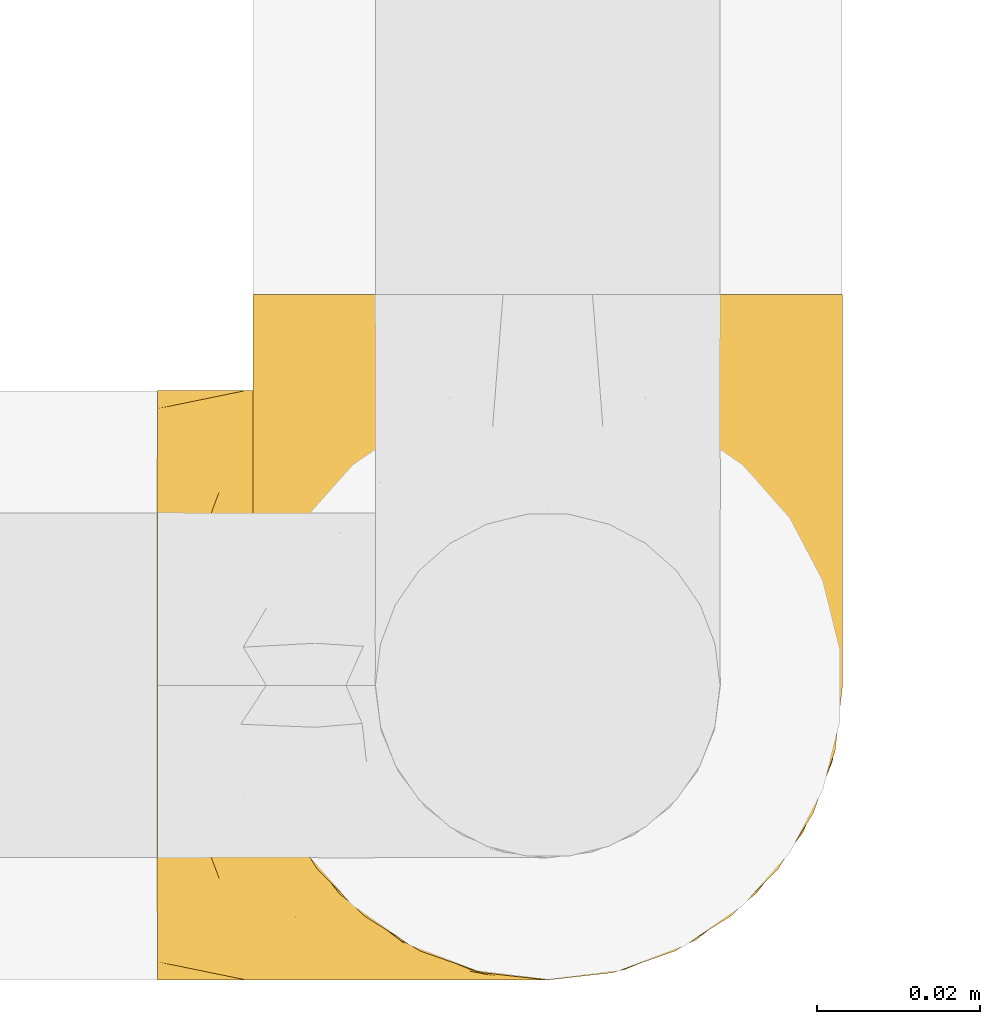
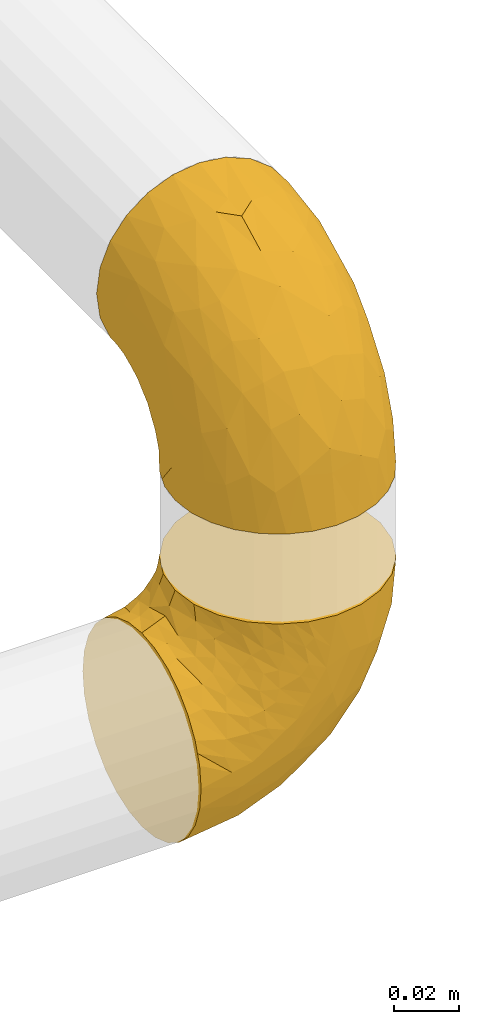
# One storey, part 16 of 39: 2 coverings.
"""IFC2X3 building model written with IfcOpenShell, lengths in millimetres."""

import ifcopenshell
import ifcopenshell.guid

model = None  # the IFC model being written
_history = None  # IfcOwnerHistory: only IFC2X3 demands one
_inside = {}  # id of a spatial element -> (the spatial element, [elements in it])
_under = {}  # id of a project, library or spatial element -> (it, [spatial elements below it])
_declared = {}  # id of a project -> (the project, [libraries it declares])
_typed = {}  # id of a type object -> (the type object, [elements of that type])
_made_of = {}  # id of a material, layer set ... -> (it, [elements and type objects made of it])


def new_model(schema):
    """Start an empty IFC model of exactly this schema.

    Asked for "IFC4X3", IfcOpenShell would pick the latest addendum, in which some entities
    have other attributes; the version numbers below select the first issue.
    IFC2X3 requires an IfcOwnerHistory on every rooted entity: one is made here for all.
    """
    global model, _history
    if schema == "IFC4X3":
        model = ifcopenshell.file(schema_version=(4, 3, 0, 0))
    else:
        model = ifcopenshell.file(schema=schema)
    _inside.clear()
    _under.clear()
    _declared.clear()
    _typed.clear()
    _made_of.clear()
    _history = None
    if model.schema == "IFC2X3":
        org = make("IfcOrganization", Name="unknown")
        user = make(
            "IfcPersonAndOrganization",
            ThePerson=make("IfcPerson", FamilyName="unknown"),
            TheOrganization=org,
        )
        app = make(
            "IfcApplication",
            ApplicationDeveloper=org,
            Version="unknown",
            ApplicationFullName="unknown",
            ApplicationIdentifier="unknown",
        )
        _history = make(
            "IfcOwnerHistory",
            OwningUser=user,
            OwningApplication=app,
            ChangeAction="ADDED",
            CreationDate=0,
        )
    return model


def make(cls, **values):
    """One entity of the class cls with the attributes given. An attribute that is None is left unset."""
    return model.create_entity(
        cls, **{name: value for name, value in values.items() if value is not None}
    )


def entity(cls, *values):
    """Any entity or typed value of the class cls, its attributes in the order of the schema. None: left unset."""
    e = model.create_entity(cls)
    for i, value in enumerate(values):
        if value is not None:
            e[i] = value
    return e


def rooted(cls, **values):
    """An entity with a GlobalId (a new one), such as an element, a storey or a relation."""
    return make(cls, GlobalId=ifcopenshell.guid.new(), OwnerHistory=_history, **values)


def si_unit(unit_type, name, prefix=None):
    """IfcSIUnit, for example si_unit("LENGTHUNIT", "METRE", prefix="MILLI")."""
    return make("IfcSIUnit", UnitType=unit_type, Prefix=prefix, Name=name)


def converted_unit(unit_type, name, factor, base, dimensions=None, offset=None):
    """IfcConversionBasedUnit, such as the inch: factor (a typed value) times the base unit."""
    return make(
        "IfcConversionBasedUnit"
        if offset is None
        else "IfcConversionBasedUnitWithOffset",
        ConversionOffset=offset,
        Dimensions=None
        if dimensions is None
        else entity("IfcDimensionalExponents", *dimensions),
        UnitType=unit_type,
        Name=name,
        ConversionFactor=make(
            "IfcMeasureWithUnit", ValueComponent=factor, UnitComponent=base
        ),
    )


def derived_unit(unit_type, elements):
    """IfcDerivedUnit: a product of units, each with its exponent."""
    return make(
        "IfcDerivedUnit",
        Elements=[
            make("IfcDerivedUnitElement", Unit=unit, Exponent=power)
            for unit, power in elements
        ],
        UnitType=unit_type,
    )


def assignment(units):
    """IfcUnitAssignment: the units of a project."""
    return None if units is None else make("IfcUnitAssignment", Units=units)


def point(xyz):
    """IfcCartesianPoint."""
    return None if xyz is None else make("IfcCartesianPoint", Coordinates=xyz)


def direction(xyz):
    """IfcDirection."""
    return None if xyz is None else make("IfcDirection", DirectionRatios=xyz)


def frame(location, z_axis=None, x_axis=None):
    """IfcAxis2Placement3D, a coordinate frame: its origin and axes. An axis left out is left unset."""
    return make(
        "IfcAxis2Placement3D",
        Location=point(location),
        Axis=direction(z_axis),
        RefDirection=direction(x_axis),
    )


def origin():
    """The frame at (0, 0, 0) with its axes left unset."""
    return frame((0.0, 0.0, 0.0))


def place(relative_to, where):
    """IfcLocalPlacement: puts the frame where relative to a parent placement (None: the world)."""
    return make(
        "IfcLocalPlacement", PlacementRelTo=relative_to, RelativePlacement=where
    )


def context(
    kind, dimensions, precision=None, world=None, true_north=None, identifier=None
):
    """IfcGeometricRepresentationContext, for example the 3D "Model" context."""
    return make(
        "IfcGeometricRepresentationContext",
        ContextIdentifier=identifier,
        ContextType=kind,
        CoordinateSpaceDimension=dimensions,
        Precision=precision,
        WorldCoordinateSystem=world,
        TrueNorth=true_north,
    )


def subcontext(parent, identifier, kind, view, scale=None):
    """IfcGeometricRepresentationSubContext, for example "Body" below "Model"."""
    return make(
        "IfcGeometricRepresentationSubContext",
        ContextIdentifier=identifier,
        ContextType=kind,
        ParentContext=parent,
        TargetScale=scale,
        TargetView=view,
    )


def project(units=None, contexts=None):
    """IfcProject with its units and contexts."""
    return rooted(
        "IfcProject",
        Name="project",
        RepresentationContexts=contexts,
        UnitsInContext=assignment(units),
    )


def spatial(cls, under=None, at=None, **own):
    """A site, building, storey or space (cls), placed at a placement, below another one or the project."""
    s = rooted(cls, ObjectPlacement=at, **own)
    if under is not None:
        _under.setdefault(under.id(), (under, []))[1].append(s)
    return s


def faces_of(points, faces, orient=None, outer=None):
    """IfcFace entities. A face is a list of loops; a loop is a list of indices into points, from 0.

    orient and outer hold one flag for each loop. By default every Orientation is true, the
    first loop of a face is its IfcFaceOuterBound and the others are IfcFaceBound.
    """
    made = []
    for i, loops in enumerate(faces):
        bounds = []
        for j, loop in enumerate(loops):
            is_outer = j == 0 if outer is None else outer[i][j]
            bounds.append(
                make(
                    "IfcFaceOuterBound" if is_outer else "IfcFaceBound",
                    Bound=make("IfcPolyLoop", Polygon=[points[k] for k in loop]),
                    Orientation=True if orient is None else orient[i][j],
                )
            )
        made.append(make("IfcFace", Bounds=bounds))
    return made


def faceted_brep(points, faces, orient=None, outer=None, voids=None):
    """IfcFacetedBrep: a solid bounded by flat faces; with voids (closed shells), ...WithVoids."""
    shared = [point(p) for p in points]
    hull = make("IfcClosedShell", CfsFaces=faces_of(shared, faces, orient, outer))
    if voids is None:
        return make("IfcFacetedBrep", Outer=hull)
    return make(
        "IfcFacetedBrepWithVoids",
        Outer=hull,
        Voids=[
            make(cls, CfsFaces=faces_of(shared, fs, o, b)) for cls, fs, o, b in voids
        ],
    )


def shape(context_of_items, identifier, shape_type, items):
    """IfcShapeRepresentation: the items that make up one representation, for example the "Body"."""
    return make(
        "IfcShapeRepresentation",
        ContextOfItems=context_of_items,
        RepresentationIdentifier=identifier,
        RepresentationType=shape_type,
        Items=items,
    )


def made_of(thing, what):
    """Note that an element or type object is made of a material, layer set ...; save() writes the relation."""
    if what is not None:
        _made_of.setdefault(what.id(), (what, []))[1].append(thing)
    return thing


def element(
    cls,
    number,
    at=None,
    inside=None,
    cuts=None,
    type_object=None,
    material=None,
    context=None,
    identifier="Body",
    shape_type=None,
    held_by="IfcProductDefinitionShape",
    body=None,
    shapes=None,
    **own,
):
    """One element of the class cls, such as IfcWall. Its Tag is "e" and its number.

    at: its placement. inside: the storey or other place that contains it. cuts: it is an
    opening in that element (IfcRelVoidsElement). A single representation is given by context,
    identifier, shape_type and body (its items); several are given by shapes. held_by: the class
    of the entity that holds the representations. save() writes the other relations.
    """
    e = rooted(cls, Tag="e%d" % number, ObjectPlacement=at, **own)
    if body is not None:
        shapes = [shape(context, identifier, shape_type, body)]
    if shapes is not None:
        e.Representation = make(held_by, Representations=shapes)
    if inside is not None:
        _inside.setdefault(inside.id(), (inside, []))[1].append(e)
    if cuts is not None:
        rooted(
            "IfcRelVoidsElement", RelatingBuildingElement=cuts, RelatedOpeningElement=e
        )
    if type_object is not None:
        _typed.setdefault(type_object.id(), (type_object, []))[1].append(e)
    return made_of(e, material)


def aggregate(whole, parts):
    """IfcRelAggregates: a whole, such as a stair, and the parts it consists of."""
    return rooted("IfcRelAggregates", RelatingObject=whole, RelatedObjects=parts)


def save(model, path):
    """Write the relations noted so far, then the file.

    IfcRelAggregates (storeys below a building ...), IfcRelContainedInSpatialStructure (elements
    in a storey), IfcRelDefinesByType, IfcRelAssociatesMaterial and IfcRelDeclares: one each for
    every whole, place, type object, material and project.
    """
    for whole, parts in _under.values():
        aggregate(whole, parts)
    for where, things in _inside.values():
        rooted(
            "IfcRelContainedInSpatialStructure",
            RelatedElements=things,
            RelatingStructure=where,
        )
    for kind, things in _typed.values():
        rooted("IfcRelDefinesByType", RelatedObjects=things, RelatingType=kind)
    for what, things in _made_of.values():
        rooted("IfcRelAssociatesMaterial", RelatedObjects=things, RelatingMaterial=what)
    for by, libraries in _declared.values():
        rooted("IfcRelDeclares", RelatingContext=by, RelatedDefinitions=libraries)
    model.write(path)


model = new_model("IFC2X3")

# Units and contexts
model_context = context("Model", 3, precision=0.01, world=origin(), true_north=direction((6.12303176911189e-17, 1.0)))
body_context = subcontext(model_context, "Body", "Model", "MODEL_VIEW")
ifc_project = project(units=[si_unit("LENGTHUNIT", "METRE", prefix="MILLI"), si_unit("AREAUNIT", "SQUARE_METRE"), si_unit("VOLUMEUNIT", "CUBIC_METRE"), converted_unit("PLANEANGLEUNIT", "DEGREE", entity("IfcRatioMeasure", 0.0174532925199433), si_unit("PLANEANGLEUNIT", "RADIAN"), dimensions=[0, 0, 0, 0, 0, 0, 0]), si_unit("MASSUNIT", "GRAM", prefix="KILO"), derived_unit("MASSDENSITYUNIT", [(si_unit("MASSUNIT", "GRAM", prefix="KILO"), 1), (si_unit("LENGTHUNIT", "METRE"), -3)]), derived_unit("MOMENTOFINERTIAUNIT", [(si_unit("LENGTHUNIT", "METRE"), 4)]), si_unit("TIMEUNIT", "SECOND"), si_unit("FREQUENCYUNIT", "HERTZ"), si_unit("THERMODYNAMICTEMPERATUREUNIT", "DEGREE_CELSIUS"), derived_unit("THERMALTRANSMITTANCEUNIT", [(si_unit("MASSUNIT", "GRAM", prefix="KILO"), 1), (si_unit("THERMODYNAMICTEMPERATUREUNIT", "KELVIN"), -1), (si_unit("TIMEUNIT", "SECOND"), -3)]), derived_unit("VOLUMETRICFLOWRATEUNIT", [(si_unit("LENGTHUNIT", "METRE"), 3), (si_unit("TIMEUNIT", "SECOND"), -1)]), derived_unit("MASSFLOWRATEUNIT", [(si_unit("MASSUNIT", "GRAM", prefix="KILO"), 1), (si_unit("TIMEUNIT", "SECOND"), -1)]), derived_unit("ROTATIONALFREQUENCYUNIT", [(si_unit("TIMEUNIT", "SECOND"), -1)]), si_unit("ELECTRICCURRENTUNIT", "AMPERE"), si_unit("ELECTRICVOLTAGEUNIT", "VOLT"), si_unit("POWERUNIT", "WATT"), si_unit("FORCEUNIT", "NEWTON", prefix="KILO"), si_unit("ILLUMINANCEUNIT", "LUX"), si_unit("LUMINOUSFLUXUNIT", "LUMEN"), si_unit("LUMINOUSINTENSITYUNIT", "CANDELA"), derived_unit("USERDEFINED", [(si_unit("MASSUNIT", "GRAM", prefix="KILO"), -1), (si_unit("LENGTHUNIT", "METRE"), -2), (si_unit("TIMEUNIT", "SECOND"), 3), (si_unit("LUMINOUSFLUXUNIT", "LUMEN"), 1)]), derived_unit("LINEARVELOCITYUNIT", [(si_unit("LENGTHUNIT", "METRE"), 1), (si_unit("TIMEUNIT", "SECOND"), -1)]), si_unit("PRESSUREUNIT", "PASCAL"), derived_unit("USERDEFINED", [(si_unit("LENGTHUNIT", "METRE"), -2), (si_unit("MASSUNIT", "GRAM", prefix="KILO"), 1), (si_unit("TIMEUNIT", "SECOND"), -2)]), derived_unit("LINEARFORCEUNIT", [(si_unit("MASSUNIT", "GRAM", prefix="KILO"), 1), (si_unit("LENGTHUNIT", "METRE"), 1), (si_unit("TIMEUNIT", "SECOND"), -2), (si_unit("LENGTHUNIT", "METRE"), -1)]), derived_unit("PLANARFORCEUNIT", [(si_unit("MASSUNIT", "GRAM", prefix="KILO"), 1), (si_unit("LENGTHUNIT", "METRE"), 1), (si_unit("TIMEUNIT", "SECOND"), -2), (si_unit("LENGTHUNIT", "METRE"), -2)])], contexts=[model_context])

# Site, building, storey
site_placement = place(None, origin())
site = spatial("IfcSite", under=ifc_project, at=site_placement, CompositionType="ELEMENT")
building_placement = place(site_placement, origin())
building = spatial("IfcBuilding", under=site, at=building_placement, CompositionType="ELEMENT")
storey_placement = place(building_placement, frame((0.0, 0.0, 24000.0)))
storey = spatial("IfcBuildingStorey", under=building, at=storey_placement, Name="07", CompositionType="ELEMENT", Elevation=24000.0)

# Coverings
covering_1_placement = place(storey_placement, frame((68632.28, 1393.38, 2980.36)))
element("IfcCovering", 1, at=covering_1_placement, inside=storey, Name=":ADSK_", ObjectType=":ADSK_", PredefinedType="INSULATION", context=body_context, shape_type="Brep", body=[
    faceted_brep([(74.0, 37.8, 1.6), (73.09, 29.74, 1.6), (70.41, 22.08, 1.6), (66.09, 15.22, 1.6), (60.36, 9.49, 1.6), (53.5, 5.18, 1.6), (45.85, 2.5, 1.6), (37.8, 1.6, 1.6), (29.74, 2.5, 1.6), (22.08, 5.18, 1.6), (15.22, 9.5, 1.6), (9.49, 15.23, 1.6), (5.18, 22.09, 1.6), (2.5, 29.74, 1.6), (1.6, 37.8, 1.6), (2.19, 43.06, 1.6), (2.5, 45.85, 1.6), (3.84, 49.68, 1.6), (5.18, 53.51, 1.6), (9.5, 60.37, 1.6), (15.23, 66.1, 1.6), (22.09, 70.41, 1.6), (29.74, 73.09, 1.6), (37.8, 74.0, 1.6), (45.85, 73.09, 1.6), (53.51, 70.41, 1.6), (60.37, 66.09, 1.6), (66.1, 60.36, 1.6), (70.41, 53.5, 1.6), (71.75, 49.67, 1.6), (73.09, 45.85, 1.6), (73.4, 43.06, 1.6), (28.43, 85.8, 14.63), (19.7, 85.8, 18.25), (12.2, 85.8, 24.0), (9.32, 85.8, 27.75), (6.45, 85.8, 31.5), (4.64, 85.8, 35.86), (2.83, 85.8, 40.23), (2.29, 85.8, 44.31), (1.94, 85.8, 46.95), (1.6, 85.8, 49.6), (2.83, 85.8, 58.96), (6.45, 85.8, 67.7), (12.2, 85.8, 75.19), (19.7, 85.8, 80.95), (28.43, 85.8, 84.56), (37.8, 85.8, 85.8), (47.16, 85.8, 84.56), (55.9, 85.8, 80.95), (63.39, 85.8, 75.19), (69.15, 85.8, 67.7), (72.76, 85.8, 58.96), (74.0, 85.8, 49.6), (73.3, 85.8, 44.31), (72.76, 85.8, 40.23), (70.95, 85.8, 35.86), (69.15, 85.8, 31.5), (66.27, 85.8, 27.75), (63.39, 85.8, 24.0), (55.9, 85.8, 18.25), (47.16, 85.8, 14.63), (37.8, 85.8, 13.4), (50.11, 27.78, 59.61), (37.8, 26.99, 60.4), (46.44, 19.15, 51.32), (37.8, 59.78, 81.67), (44.03, 64.45, 82.49), (37.8, 67.99, 82.98), (47.59, 45.3, 73.87), (57.17, 53.86, 73.39), (50.38, 66.01, 81.11), (58.65, 70.92, 77.75), (73.37, 33.16, 16.46), (71.27, 49.16, 51.34), (70.16, 68.28, 63.37), (66.97, 50.64, 61.46), (73.22, 70.36, 54.83), (74.0, 67.43, 45.94), (74.0, 74.88, 47.42), (74.0, 77.61, 47.97), (74.0, 80.34, 48.51), (64.86, 65.68, 70.77), (70.93, 24.84, 15.75), (45.19, 11.5, 39.56), (48.57, 5.67, 21.48), (54.32, 13.35, 36.01), (72.94, 39.73, 34.58), (74.0, 41.45, 19.96), (74.0, 44.05, 23.86), (74.0, 46.65, 27.75), (74.0, 49.25, 31.64), (74.0, 51.85, 35.54), (68.72, 35.98, 46.13), (73.34, 57.18, 48.41), (67.28, 18.48, 16.74), (61.7, 13.36, 21.75), (55.94, 7.85, 16.31), (37.8, 4.42, 19.4), (53.02, 20.15, 48.77), (57.31, 31.91, 58.66), (74.0, 38.88, 7.05), (74.0, 39.97, 12.51), (64.86, 21.9, 34.87), (59.15, 22.4, 45.71), (70.05, 28.44, 30.95), (55.98, 41.69, 67.5), (37.8, 48.04, 75.69), (63.54, 33.67, 53.35), (61.4, 44.49, 64.73), (37.8, 5.72, 27.61), (37.8, 17.68, 51.09), (37.8, 11.7, 39.35), (74.0, 55.75, 38.14), (74.0, 59.64, 40.74), (74.0, 63.53, 43.34), (37.8, 36.3, 69.71), (70.9, 69.92, 30.92), (69.2, 69.03, 26.47), (65.83, 74.68, 24.1), (73.31, 79.55, 42.08), (67.07, 79.54, 27.56), (62.53, 81.25, 22.68), (52.3, 76.19, 12.9), (54.94, 72.4, 10.56), (46.54, 75.54, 9.38), (72.08, 63.7, 30.49), (73.17, 66.91, 37.21), (59.32, 72.9, 15.4), (56.36, 77.88, 16.56), (48.99, 80.8, 14.21), (58.36, 80.78, 19.1), (66.05, 60.93, 6.65), (61.56, 66.56, 9.22), (68.98, 58.7, 13.56), (73.26, 46.01, 10.43), (70.05, 80.23, 32.68), (73.39, 70.42, 40.02), (70.87, 74.75, 33.01), (61.17, 68.99, 13.09), (71.9, 51.42, 11.85), (65.19, 71.01, 20.93), (37.8, 76.08, 6.64), (46.04, 73.72, 5.68), (52.15, 71.61, 5.7), (66.57, 63.33, 14.76), (37.8, 77.45, 9.94), (73.34, 52.1, 25.2), (72.91, 50.98, 19.66), (37.8, 80.75, 11.31), (72.75, 76.87, 39.13), (70.14, 63.89, 24.56), (72.14, 57.77, 25.09), (66.28, 66.53, 18.54), (73.22, 57.73, 30.86), (17.23, 80.78, 19.1), (26.6, 80.8, 14.22), (13.06, 81.26, 22.68), (1.6, 38.88, 7.05), (1.6, 39.97, 12.51), (29.56, 73.72, 5.68), (20.66, 72.41, 10.57), (23.45, 71.61, 5.7), (14.04, 66.57, 9.22), (1.6, 74.88, 47.42), (1.6, 80.34, 48.51), (1.6, 83.07, 49.05), (19.23, 77.88, 16.56), (23.3, 76.2, 12.9), (16.29, 72.91, 15.39), (8.09, 77.2, 27.52), (4.72, 74.75, 33.0), (5.54, 80.23, 32.67), (3.69, 51.43, 11.86), (2.84, 76.87, 39.13), (2.42, 66.92, 37.21), (4.69, 69.93, 30.92), (3.51, 63.71, 30.49), (2.2, 70.42, 40.02), (29.05, 75.54, 9.38), (2.29, 79.55, 42.08), (9.55, 60.94, 6.65), (14.43, 69.0, 13.09), (2.33, 46.02, 10.43), (3.45, 57.77, 25.08), (2.37, 57.73, 30.85), (5.45, 63.89, 24.56), (10.41, 71.03, 20.93), (2.81, 51.53, 19.57), (6.62, 58.72, 13.56), (1.6, 41.45, 19.96), (9.76, 74.69, 24.1), (9.03, 63.35, 14.76), (1.6, 59.64, 40.74), (4.15, 56.44, 20.0), (2.17, 51.59, 25.27), (1.6, 44.05, 23.86), (6.39, 69.03, 26.46), (1.6, 67.43, 45.94), (1.6, 63.53, 43.34), (9.32, 66.54, 18.54), (1.6, 55.75, 38.14), (1.6, 49.25, 31.64), (1.6, 46.65, 27.75), (1.6, 51.85, 35.54), (4.32, 49.16, 51.33), (2.37, 70.36, 54.83), (2.25, 57.19, 48.41), (16.43, 22.41, 45.7), (18.27, 31.92, 58.67), (12.04, 33.68, 53.34), (8.62, 50.63, 61.46), (6.87, 35.99, 46.13), (10.72, 21.91, 34.86), (2.64, 39.73, 34.58), (25.48, 27.78, 59.61), (19.59, 41.7, 67.49), (5.43, 68.28, 63.37), (31.57, 64.45, 82.49), (25.21, 66.0, 81.11), (5.53, 28.45, 30.94), (16.94, 70.92, 77.75), (10.73, 65.68, 70.77), (18.42, 53.85, 73.39), (21.26, 13.35, 36.01), (27.01, 5.67, 21.48), (30.39, 11.5, 39.57), (2.22, 33.16, 16.45), (13.88, 13.37, 21.75), (8.3, 18.49, 16.74), (28.0, 45.3, 73.87), (29.14, 19.14, 51.31), (22.56, 20.15, 48.77), (19.64, 7.85, 16.32), (14.18, 44.48, 64.71), (4.66, 24.85, 15.75)], [[[0, 1, 2, 3, 4, 5, 6, 7, 8, 9, 10, 11, 12, 13, 14, 15, 16, 17, 18, 19, 20, 21, 22, 23, 24, 25, 26, 27, 28, 29, 30, 31]], [[32, 33, 34, 35, 36, 37, 38, 39, 40, 41, 42, 43, 44, 45, 46, 47, 48, 49, 50, 51, 52, 53, 54, 55, 56, 57, 58, 59, 60, 61, 62]], [[63, 64, 65]], [[66, 67, 68]], [[69, 70, 71]], [[71, 70, 72]], [[73, 1, 0]], [[74, 75, 76]], [[49, 48, 71]], [[77, 78, 79, 80, 81, 53]], [[50, 82, 51]], [[72, 50, 49]], [[2, 1, 83]], [[84, 85, 86]], [[87, 88, 89, 90, 91, 92]], [[53, 52, 77]], [[93, 74, 76]], [[5, 85, 6]], [[94, 78, 77]], [[95, 3, 2]], [[95, 96, 3]], [[75, 51, 82]], [[85, 5, 97]], [[50, 72, 82]], [[97, 5, 4]], [[85, 98, 6]], [[94, 87, 92]], [[74, 77, 75]], [[99, 100, 63]], [[96, 4, 3]], [[73, 0, 101, 102, 88]], [[96, 103, 104]], [[48, 68, 67]], [[84, 99, 65]], [[105, 83, 73]], [[105, 95, 83]], [[100, 106, 63]], [[86, 96, 104]], [[97, 86, 85]], [[67, 107, 69]], [[100, 108, 109]], [[84, 110, 85]], [[93, 87, 74]], [[96, 95, 103]], [[69, 71, 67]], [[70, 69, 106]], [[4, 96, 97]], [[86, 97, 96]], [[83, 95, 2]], [[103, 95, 105]], [[93, 103, 105]], [[103, 108, 104]], [[75, 77, 52]], [[94, 77, 74]], [[51, 75, 52]], [[75, 82, 76]], [[109, 82, 70]], [[93, 76, 108]], [[88, 87, 73]], [[105, 73, 87]], [[84, 86, 99]], [[84, 111, 112, 110]], [[98, 85, 110]], [[98, 7, 6]], [[73, 83, 1]], [[71, 72, 49]], [[82, 72, 70]], [[87, 94, 74]], [[94, 92, 113, 114, 115, 78]], [[48, 47, 68]], [[48, 67, 71]], [[100, 104, 108]], [[99, 86, 104]], [[109, 108, 76]], [[100, 109, 106]], [[82, 109, 76]], [[106, 109, 70]], [[100, 99, 104]], [[99, 63, 65]], [[69, 116, 63]], [[111, 84, 65]], [[64, 63, 116]], [[64, 111, 65]], [[63, 106, 69]], [[103, 93, 108]], [[87, 93, 105]], [[107, 67, 66]], [[107, 116, 69]], [[117, 118, 119]], [[80, 120, 55]], [[121, 119, 122]], [[120, 56, 55]], [[123, 124, 125]], [[114, 126, 127]], [[101, 0, 31, 30, 102]], [[123, 128, 124]], [[129, 123, 130]], [[60, 122, 131]], [[132, 133, 134]], [[29, 28, 135]], [[131, 61, 60]], [[122, 60, 59]], [[136, 137, 138]], [[124, 128, 139]], [[132, 27, 26]], [[131, 130, 61]], [[140, 135, 28]], [[102, 29, 135]], [[119, 118, 141]], [[58, 136, 121]], [[140, 28, 27]], [[54, 53, 81, 80, 55]], [[23, 142, 143]], [[24, 144, 25]], [[25, 144, 133]], [[26, 25, 133]], [[134, 133, 145]], [[125, 142, 146]], [[124, 143, 125]], [[147, 90, 148]], [[124, 144, 143]], [[149, 125, 146]], [[150, 57, 56]], [[137, 78, 115]], [[130, 62, 61]], [[132, 140, 27]], [[151, 152, 153]], [[140, 134, 148]], [[148, 89, 140]], [[120, 78, 150]], [[115, 127, 137]], [[137, 136, 150]], [[78, 120, 80, 79]], [[150, 56, 120]], [[91, 154, 92]], [[127, 117, 138]], [[144, 24, 143]], [[133, 144, 124]], [[152, 91, 147]], [[145, 152, 134]], [[23, 143, 24]], [[142, 125, 143]], [[130, 125, 149]], [[128, 123, 129]], [[141, 129, 119]], [[124, 139, 133]], [[125, 130, 123]], [[62, 130, 149]], [[128, 153, 139]], [[145, 139, 153]], [[92, 154, 113]], [[127, 115, 114]], [[117, 127, 126]], [[118, 117, 126]], [[121, 117, 119]], [[138, 137, 127]], [[78, 137, 150]], [[151, 118, 126]], [[118, 151, 141]], [[153, 128, 141]], [[129, 141, 128]], [[102, 30, 29]], [[140, 88, 135]], [[88, 102, 135]], [[133, 132, 26]], [[140, 132, 134]], [[121, 122, 59]], [[131, 119, 129]], [[121, 59, 58]], [[121, 138, 117]], [[136, 58, 57]], [[150, 136, 57]], [[121, 136, 138]], [[119, 131, 122]], [[131, 129, 130]], [[139, 145, 133]], [[152, 145, 153]], [[89, 148, 90]], [[89, 88, 140]], [[147, 134, 152]], [[134, 147, 148]], [[126, 114, 113]], [[152, 154, 91]], [[91, 90, 147]], [[151, 153, 141]], [[154, 151, 126]], [[151, 154, 152]], [[113, 154, 126]], [[155, 32, 156]], [[33, 157, 34]], [[62, 149, 156]], [[15, 14, 158, 159, 16]], [[160, 23, 22]], [[161, 162, 163]], [[40, 39, 38, 164, 165, 166, 41]], [[167, 168, 169]], [[157, 170, 34]], [[171, 172, 170]], [[18, 173, 19]], [[174, 37, 36]], [[175, 176, 177]], [[178, 171, 175]], [[146, 179, 149]], [[168, 179, 161]], [[161, 160, 162]], [[162, 160, 22]], [[38, 37, 180]], [[20, 19, 181]], [[21, 20, 163]], [[161, 182, 169]], [[18, 183, 173]], [[184, 185, 186]], [[169, 187, 167]], [[188, 189, 173]], [[159, 190, 183]], [[17, 159, 183]], [[156, 179, 168]], [[191, 157, 155]], [[192, 163, 189]], [[21, 162, 22]], [[146, 142, 179]], [[181, 163, 20]], [[193, 175, 177]], [[178, 172, 171]], [[167, 156, 168]], [[184, 194, 195]], [[181, 173, 189]], [[173, 196, 188]], [[197, 186, 177]], [[198, 164, 180]], [[180, 164, 38]], [[199, 178, 175]], [[37, 174, 180]], [[198, 180, 174]], [[175, 193, 199]], [[177, 176, 197]], [[163, 162, 21]], [[160, 161, 179]], [[192, 184, 200]], [[194, 189, 188]], [[179, 142, 160]], [[23, 160, 142]], [[169, 168, 161]], [[155, 156, 167]], [[182, 161, 163]], [[200, 186, 187]], [[62, 156, 32]], [[179, 156, 149]], [[192, 182, 163]], [[200, 169, 182]], [[176, 175, 171]], [[174, 178, 198]], [[185, 201, 177]], [[170, 176, 171]], [[197, 176, 191]], [[198, 178, 199]], [[178, 174, 172]], [[187, 197, 191]], [[197, 187, 186]], [[167, 187, 191]], [[169, 200, 187]], [[173, 183, 190]], [[17, 16, 159]], [[173, 181, 19]], [[163, 181, 189]], [[155, 157, 33]], [[170, 157, 191]], [[176, 170, 191]], [[35, 170, 172]], [[35, 172, 36]], [[34, 170, 35]], [[174, 36, 172]], [[32, 155, 33]], [[191, 155, 167]], [[192, 189, 194]], [[182, 192, 200]], [[185, 184, 202]], [[183, 18, 17]], [[196, 173, 190]], [[196, 203, 188]], [[201, 193, 177]], [[200, 184, 186]], [[188, 195, 194]], [[204, 185, 202]], [[188, 203, 195]], [[192, 194, 184]], [[203, 202, 195]], [[184, 195, 202]], [[201, 185, 204]], [[186, 185, 177]], [[205, 206, 207]], [[208, 209, 210]], [[210, 211, 212]], [[210, 213, 208]], [[214, 204, 202, 203, 196, 190]], [[206, 41, 166, 165, 164, 198]], [[215, 216, 209]], [[206, 217, 42]], [[218, 46, 219]], [[207, 214, 205]], [[212, 214, 220]], [[221, 219, 45]], [[45, 219, 46]], [[221, 222, 223]], [[224, 225, 226]], [[222, 44, 43]], [[222, 217, 211]], [[220, 214, 227]], [[227, 190, 159, 158, 14]], [[217, 43, 42]], [[14, 13, 227]], [[225, 9, 8]], [[10, 228, 11]], [[11, 229, 12]], [[208, 213, 228]], [[228, 229, 11]], [[230, 219, 223]], [[231, 232, 226]], [[231, 64, 215]], [[225, 233, 9]], [[229, 213, 220]], [[233, 10, 9]], [[110, 225, 98]], [[41, 206, 42]], [[222, 211, 234]], [[224, 228, 233]], [[225, 8, 98]], [[221, 45, 44]], [[226, 110, 112, 111]], [[12, 229, 235]], [[46, 218, 68]], [[230, 107, 218]], [[223, 234, 216]], [[107, 66, 218]], [[224, 233, 225]], [[228, 10, 233]], [[213, 229, 228]], [[235, 229, 220]], [[208, 228, 224]], [[212, 213, 210]], [[207, 206, 198]], [[205, 211, 217]], [[205, 217, 206]], [[43, 217, 222]], [[212, 211, 205]], [[210, 209, 234]], [[227, 13, 235]], [[214, 190, 227]], [[110, 226, 225]], [[232, 231, 215]], [[8, 7, 98]], [[227, 235, 220]], [[13, 12, 235]], [[222, 221, 44]], [[219, 221, 223]], [[207, 198, 199, 193, 201, 204]], [[214, 207, 204]], [[68, 218, 66]], [[68, 47, 46]], [[230, 218, 219]], [[224, 232, 208]], [[208, 232, 209]], [[216, 215, 230]], [[210, 234, 211]], [[216, 234, 209]], [[222, 234, 223]], [[226, 232, 224]], [[209, 232, 215]], [[226, 111, 231]], [[64, 116, 215]], [[231, 111, 64]], [[116, 230, 215]], [[230, 223, 216]], [[214, 212, 205]], [[213, 212, 220]], [[230, 116, 107]]]),
])
covering_2_placement = place(storey_placement, frame((68620.51, 1393.38, 2862.63)))
element("IfcCovering", 2, at=covering_2_placement, inside=storey, Name=":ADSK_", ObjectType=":ADSK_", PredefinedType="INSULATION", context=body_context, shape_type="Brep", body=[
    faceted_brep([(1.6, 37.8, 74.0), (1.6, 45.85, 73.09), (1.6, 53.51, 70.41), (1.61, 60.37, 66.09), (1.62, 66.1, 60.36), (1.64, 70.41, 53.5), (1.64, 71.75, 49.67), (1.65, 73.09, 45.85), (1.66, 73.4, 43.06), (1.67, 74.0, 37.8), (1.68, 73.09, 29.74), (1.7, 70.41, 22.08), (1.71, 66.09, 15.22), (1.72, 60.36, 9.49), (1.73, 53.5, 5.18), (1.74, 45.85, 2.5), (1.74, 37.8, 1.6), (1.74, 29.74, 2.5), (1.73, 22.08, 5.18), (1.72, 15.22, 9.5), (1.71, 9.49, 15.23), (1.7, 5.18, 22.09), (1.68, 2.5, 29.74), (1.67, 1.6, 37.8), (1.66, 2.19, 43.06), (1.65, 2.5, 45.85), (1.64, 3.84, 49.68), (1.64, 5.18, 53.51), (1.62, 9.5, 60.37), (1.61, 15.23, 66.1), (1.6, 22.09, 70.41), (1.6, 29.74, 73.09), (14.61, 28.43, 85.8), (18.22, 19.7, 85.8), (23.97, 12.2, 85.8), (27.72, 9.32, 85.8), (31.47, 6.45, 85.8), (35.84, 4.64, 85.8), (40.2, 2.83, 85.8), (44.28, 2.29, 85.8), (46.93, 1.94, 85.8), (49.57, 1.6, 85.8), (58.94, 2.83, 85.8), (67.67, 6.45, 85.8), (75.17, 12.2, 85.8), (80.92, 19.7, 85.8), (84.54, 28.43, 85.8), (85.77, 37.8, 85.8), (84.54, 47.16, 85.8), (80.92, 55.9, 85.8), (75.17, 63.39, 85.8), (67.67, 69.15, 85.8), (58.94, 72.76, 85.8), (49.57, 74.0, 85.8), (44.28, 73.3, 85.8), (40.2, 72.76, 85.8), (35.84, 70.95, 85.8), (31.47, 69.15, 85.8), (27.72, 66.27, 85.8), (23.97, 63.39, 85.8), (18.22, 55.9, 85.8), (14.61, 47.16, 85.8), (13.37, 37.8, 85.8), (59.65, 50.1, 27.84), (60.44, 37.8, 27.05), (51.35, 46.47, 19.2), (81.66, 37.8, 59.81), (82.47, 44.03, 64.47), (82.96, 37.8, 67.99), (73.85, 47.6, 45.31), (73.38, 57.17, 53.89), (81.09, 50.38, 66.02), (77.72, 58.65, 70.94), (16.51, 73.37, 33.19), (51.34, 71.27, 49.2), (63.34, 70.17, 68.28), (61.44, 66.97, 50.65), (54.81, 73.23, 70.38), (45.93, 74.0, 67.45), (47.4, 74.0, 74.88), (47.95, 74.0, 77.61), (48.49, 74.0, 80.34), (70.74, 64.87, 65.69), (15.84, 70.93, 24.86), (39.67, 45.21, 11.57), (21.61, 48.57, 5.7), (36.11, 54.32, 13.41), (34.61, 72.95, 39.77), (20.01, 74.0, 41.48), (23.89, 74.0, 44.08), (27.78, 74.0, 46.68), (31.66, 74.0, 49.29), (35.55, 74.0, 51.89), (46.16, 68.72, 36.04), (48.4, 73.34, 57.21), (16.85, 67.28, 18.51), (21.86, 61.7, 13.4), (16.44, 55.94, 7.88), (19.54, 37.8, 4.45), (48.85, 53.03, 20.22), (58.76, 57.31, 32.04), (7.12, 74.0, 38.89), (12.58, 74.0, 39.99), (34.98, 64.86, 21.97), (45.79, 59.15, 22.48), (31.0, 70.06, 28.49), (67.5, 56.07, 41.82), (75.7, 37.8, 48.08), (53.36, 63.55, 33.73), (64.69, 61.44, 44.52), (27.72, 37.8, 5.76), (51.14, 37.8, 17.74), (39.43, 37.8, 11.75), (38.14, 74.0, 55.78), (40.74, 74.0, 59.67), (43.33, 74.0, 63.56), (69.73, 37.8, 36.36), (30.92, 70.9, 69.93), (26.45, 69.19, 69.07), (24.07, 65.81, 74.72), (42.06, 73.3, 79.55), (27.53, 67.07, 79.55), (22.65, 62.52, 81.27), (12.88, 52.28, 76.21), (10.57, 54.94, 72.42), (9.37, 46.54, 75.55), (39.11, 72.75, 76.87), (15.37, 59.27, 72.94), (16.53, 56.35, 77.89), (14.2, 48.99, 80.81), (19.07, 58.35, 80.79), (6.68, 66.05, 60.94), (9.23, 61.55, 66.58), (13.58, 68.98, 58.73), (10.47, 73.26, 46.04), (32.65, 70.05, 80.24), (40.01, 73.39, 70.43), (32.97, 70.87, 74.77), (13.1, 61.17, 69.01), (11.9, 71.9, 51.44), (20.92, 65.18, 71.05), (6.63, 37.8, 76.09), (5.67, 46.04, 73.72), (5.71, 52.15, 71.62), (14.77, 66.56, 63.37), (9.92, 37.8, 77.46), (25.22, 73.34, 52.11), (19.7, 72.92, 51.0), (11.29, 37.8, 80.75), (24.56, 70.14, 63.9), (25.07, 72.14, 57.78), (18.55, 66.27, 66.56), (28.88, 72.52, 59.68), (37.2, 73.17, 66.94), (30.47, 72.07, 63.74), (19.07, 17.24, 80.79), (14.2, 26.59, 80.81), (22.65, 13.08, 81.28), (7.12, 1.6, 38.89), (12.58, 1.6, 39.99), (5.67, 29.56, 73.72), (10.57, 20.66, 72.43), (5.71, 23.45, 71.62), (9.23, 14.05, 66.59), (49.03, 1.6, 83.07), (47.4, 1.6, 74.88), (48.49, 1.6, 80.34), (16.53, 19.24, 77.9), (12.88, 23.32, 76.22), (15.36, 16.35, 72.96), (27.49, 8.1, 77.24), (32.97, 4.72, 74.77), (32.65, 5.54, 80.24), (11.91, 3.69, 51.45), (39.11, 2.84, 76.87), (37.2, 2.42, 66.94), (30.92, 4.69, 69.94), (30.47, 3.52, 63.75), (40.01, 2.2, 70.43), (9.37, 29.06, 75.56), (42.06, 2.29, 79.55), (6.68, 9.55, 60.95), (13.1, 14.43, 69.02), (10.47, 2.33, 46.04), (24.56, 5.45, 63.89), (28.89, 3.06, 59.67), (20.92, 10.41, 71.06), (19.6, 2.81, 51.57), (13.58, 6.62, 58.74), (20.01, 1.6, 41.48), (24.06, 9.78, 74.72), (14.77, 9.04, 63.38), (25.06, 3.45, 57.79), (35.55, 1.6, 51.89), (23.89, 1.6, 44.08), (40.74, 1.6, 59.67), (38.14, 1.6, 55.78), (18.55, 9.33, 66.58), (45.93, 1.6, 67.45), (43.33, 1.6, 63.56), (26.44, 6.4, 69.07), (20.0, 4.16, 56.48), (27.78, 1.6, 46.68), (25.32, 2.17, 51.64), (31.66, 1.6, 49.29), (51.33, 4.31, 49.21), (54.81, 2.36, 70.38), (48.4, 2.25, 57.22), (45.78, 16.43, 22.48), (58.77, 18.27, 32.05), (53.36, 12.03, 33.74), (61.44, 8.62, 50.64), (46.15, 6.86, 36.05), (34.97, 10.72, 21.98), (34.6, 2.64, 39.78), (59.64, 25.49, 27.84), (67.49, 19.5, 41.82), (63.34, 5.42, 68.28), (82.47, 31.56, 64.47), (81.09, 25.21, 66.01), (31.0, 5.53, 28.5), (77.72, 16.94, 70.93), (70.74, 10.72, 65.69), (73.38, 18.42, 53.88), (36.11, 21.26, 13.41), (21.61, 27.01, 5.71), (39.68, 30.38, 11.57), (16.51, 2.22, 33.19), (21.86, 13.88, 13.41), (16.85, 8.3, 18.52), (73.85, 27.99, 45.31), (51.35, 29.1, 19.2), (48.85, 22.55, 20.23), (16.45, 19.64, 7.88), (64.67, 14.14, 44.51), (15.84, 4.66, 24.87)], [[[0, 1, 2, 3, 4, 5, 6, 7, 8, 9, 10, 11, 12, 13, 14, 15, 16, 17, 18, 19, 20, 21, 22, 23, 24, 25, 26, 27, 28, 29, 30, 31]], [[32, 33, 34, 35, 36, 37, 38, 39, 40, 41, 42, 43, 44, 45, 46, 47, 48, 49, 50, 51, 52, 53, 54, 55, 56, 57, 58, 59, 60, 61, 62]], [[63, 64, 65]], [[66, 67, 68]], [[69, 70, 71]], [[71, 70, 72]], [[73, 10, 9]], [[74, 75, 76]], [[49, 48, 71]], [[77, 78, 79, 80, 81, 53]], [[50, 82, 51]], [[72, 50, 49]], [[11, 10, 83]], [[84, 85, 86]], [[87, 88, 89, 90, 91, 92]], [[53, 52, 77]], [[93, 74, 76]], [[14, 85, 15]], [[94, 78, 77]], [[95, 12, 11]], [[95, 96, 12]], [[75, 51, 82]], [[85, 14, 97]], [[50, 72, 82]], [[97, 14, 13]], [[85, 98, 15]], [[94, 87, 92]], [[74, 77, 75]], [[99, 100, 63]], [[96, 13, 12]], [[73, 9, 101, 102, 88]], [[96, 103, 104]], [[48, 68, 67]], [[84, 99, 65]], [[105, 83, 73]], [[105, 95, 83]], [[100, 106, 63]], [[86, 96, 104]], [[97, 86, 85]], [[67, 107, 69]], [[100, 108, 109]], [[84, 110, 85]], [[93, 87, 74]], [[96, 95, 103]], [[69, 71, 67]], [[70, 69, 106]], [[13, 96, 97]], [[86, 97, 96]], [[83, 95, 11]], [[103, 95, 105]], [[93, 103, 105]], [[103, 108, 104]], [[75, 77, 52]], [[94, 77, 74]], [[51, 75, 52]], [[75, 82, 76]], [[109, 82, 70]], [[93, 76, 108]], [[88, 87, 73]], [[105, 73, 87]], [[84, 86, 99]], [[84, 111, 112, 110]], [[98, 85, 110]], [[98, 16, 15]], [[73, 83, 10]], [[71, 72, 49]], [[82, 72, 70]], [[87, 94, 74]], [[94, 92, 113, 114, 115, 78]], [[48, 47, 68]], [[48, 67, 71]], [[100, 104, 108]], [[99, 86, 104]], [[109, 108, 76]], [[100, 109, 106]], [[82, 109, 76]], [[106, 109, 70]], [[100, 99, 104]], [[99, 63, 65]], [[69, 116, 63]], [[111, 84, 65]], [[64, 63, 116]], [[64, 111, 65]], [[63, 106, 69]], [[103, 93, 108]], [[87, 93, 105]], [[107, 67, 66]], [[107, 116, 69]], [[117, 118, 119]], [[80, 120, 55]], [[121, 119, 122]], [[120, 56, 55]], [[123, 124, 125]], [[126, 57, 56]], [[101, 9, 8, 7, 102]], [[123, 127, 124]], [[128, 123, 129]], [[60, 122, 130]], [[131, 132, 133]], [[6, 5, 134]], [[130, 61, 60]], [[122, 60, 59]], [[135, 136, 137]], [[124, 127, 138]], [[131, 4, 3]], [[130, 129, 61]], [[139, 134, 5]], [[102, 6, 134]], [[119, 118, 140]], [[58, 135, 121]], [[139, 5, 4]], [[54, 53, 81, 80, 55]], [[0, 141, 142]], [[1, 143, 2]], [[2, 143, 132]], [[3, 2, 132]], [[133, 132, 144]], [[125, 141, 145]], [[124, 142, 125]], [[146, 90, 147]], [[124, 143, 142]], [[148, 125, 145]], [[129, 62, 61]], [[131, 139, 4]], [[149, 150, 151]], [[139, 133, 147]], [[147, 89, 139]], [[136, 78, 115]], [[150, 149, 152]], [[120, 78, 126]], [[115, 153, 136]], [[136, 135, 126]], [[78, 120, 80, 79]], [[126, 56, 120]], [[154, 114, 113]], [[153, 117, 137]], [[143, 1, 142]], [[132, 143, 124]], [[150, 91, 146]], [[144, 150, 133]], [[0, 142, 1]], [[141, 125, 142]], [[129, 125, 148]], [[127, 123, 128]], [[125, 129, 123]], [[62, 129, 148]], [[140, 128, 119]], [[124, 138, 132]], [[127, 151, 138]], [[144, 138, 151]], [[149, 151, 140]], [[153, 115, 114]], [[117, 153, 154]], [[118, 117, 154]], [[121, 117, 119]], [[137, 136, 153]], [[78, 136, 126]], [[149, 118, 154]], [[118, 149, 140]], [[151, 127, 140]], [[128, 140, 127]], [[102, 7, 6]], [[139, 88, 134]], [[88, 102, 134]], [[132, 131, 3]], [[139, 131, 133]], [[121, 122, 59]], [[130, 119, 128]], [[121, 59, 58]], [[121, 137, 117]], [[135, 58, 57]], [[126, 135, 57]], [[121, 135, 137]], [[119, 130, 122]], [[130, 128, 129]], [[138, 144, 132]], [[150, 144, 151]], [[89, 147, 90]], [[89, 88, 139]], [[146, 133, 150]], [[133, 146, 147]], [[114, 154, 153]], [[91, 150, 92]], [[91, 90, 146]], [[92, 152, 113]], [[152, 149, 154]], [[113, 152, 154]], [[92, 150, 152]], [[155, 32, 156]], [[33, 157, 34]], [[62, 148, 156]], [[24, 23, 158, 159, 25]], [[160, 0, 31]], [[161, 162, 163]], [[164, 41, 40, 39, 38, 165, 166]], [[167, 168, 169]], [[157, 170, 34]], [[171, 172, 170]], [[27, 173, 28]], [[174, 37, 36]], [[175, 176, 177]], [[178, 171, 175]], [[145, 179, 148]], [[168, 179, 161]], [[161, 160, 162]], [[162, 160, 31]], [[38, 37, 180]], [[29, 28, 181]], [[30, 29, 163]], [[161, 182, 169]], [[27, 183, 173]], [[177, 184, 185]], [[169, 186, 167]], [[187, 188, 173]], [[159, 189, 183]], [[26, 159, 183]], [[156, 179, 168]], [[190, 157, 155]], [[191, 163, 188]], [[30, 162, 31]], [[145, 141, 179]], [[181, 163, 29]], [[167, 156, 168]], [[192, 193, 185]], [[181, 173, 188]], [[173, 194, 187]], [[195, 177, 196]], [[170, 172, 35]], [[197, 192, 184]], [[198, 165, 180]], [[180, 165, 38]], [[199, 178, 175]], [[37, 174, 180]], [[198, 180, 174]], [[175, 195, 199]], [[177, 176, 200]], [[163, 162, 30]], [[160, 161, 179]], [[191, 192, 197]], [[201, 188, 187]], [[179, 141, 160]], [[0, 160, 141]], [[169, 168, 161]], [[155, 156, 167]], [[182, 161, 163]], [[197, 184, 186]], [[62, 156, 32]], [[179, 156, 148]], [[191, 182, 163]], [[197, 169, 182]], [[176, 175, 171]], [[174, 178, 198]], [[195, 175, 177]], [[170, 176, 171]], [[200, 176, 190]], [[198, 178, 199]], [[178, 174, 172]], [[186, 200, 190]], [[200, 186, 184]], [[167, 186, 190]], [[169, 197, 186]], [[173, 183, 189]], [[26, 25, 159]], [[173, 181, 28]], [[163, 181, 188]], [[155, 157, 33]], [[170, 157, 190]], [[176, 170, 190]], [[172, 36, 35]], [[172, 174, 36]], [[34, 170, 35]], [[172, 171, 178]], [[32, 155, 33]], [[190, 155, 167]], [[191, 188, 201]], [[182, 191, 197]], [[185, 196, 177]], [[183, 27, 26]], [[194, 173, 189]], [[194, 202, 187]], [[185, 184, 192]], [[200, 184, 177]], [[192, 201, 203]], [[196, 185, 193]], [[187, 203, 201]], [[204, 193, 192]], [[187, 202, 203]], [[191, 201, 192]], [[202, 204, 203]], [[192, 203, 204]], [[205, 206, 207]], [[208, 209, 210]], [[210, 211, 212]], [[210, 213, 208]], [[214, 193, 204, 202, 194, 189]], [[206, 41, 164, 166, 165, 198]], [[215, 216, 209]], [[206, 217, 42]], [[218, 46, 219]], [[207, 214, 205]], [[212, 214, 220]], [[221, 219, 45]], [[45, 219, 46]], [[221, 222, 223]], [[224, 225, 226]], [[222, 44, 43]], [[222, 217, 211]], [[220, 214, 227]], [[227, 189, 159, 158, 23]], [[217, 43, 42]], [[23, 22, 227]], [[225, 18, 17]], [[19, 228, 20]], [[20, 229, 21]], [[208, 213, 228]], [[228, 229, 20]], [[230, 219, 223]], [[231, 232, 226]], [[231, 64, 215]], [[225, 233, 18]], [[229, 213, 220]], [[233, 19, 18]], [[110, 225, 98]], [[41, 206, 42]], [[222, 211, 234]], [[224, 228, 233]], [[225, 17, 98]], [[221, 45, 44]], [[226, 110, 112, 111]], [[21, 229, 235]], [[46, 218, 68]], [[230, 107, 218]], [[223, 234, 216]], [[107, 66, 218]], [[224, 233, 225]], [[228, 19, 233]], [[213, 229, 228]], [[235, 229, 220]], [[208, 228, 224]], [[212, 213, 210]], [[207, 206, 198]], [[205, 211, 217]], [[205, 217, 206]], [[43, 217, 222]], [[212, 211, 205]], [[210, 209, 234]], [[227, 22, 235]], [[214, 189, 227]], [[110, 226, 225]], [[232, 231, 215]], [[17, 16, 98]], [[227, 235, 220]], [[22, 21, 235]], [[222, 221, 44]], [[219, 221, 223]], [[207, 198, 199, 195, 196, 193]], [[214, 207, 193]], [[68, 218, 66]], [[68, 47, 46]], [[230, 218, 219]], [[224, 232, 208]], [[208, 232, 209]], [[216, 215, 230]], [[210, 234, 211]], [[216, 234, 209]], [[222, 234, 223]], [[226, 232, 224]], [[209, 232, 215]], [[226, 111, 231]], [[64, 116, 215]], [[231, 111, 64]], [[116, 230, 215]], [[230, 223, 216]], [[214, 212, 205]], [[213, 212, 220]], [[230, 116, 107]]]),
])

save(model, "model.ifc")
